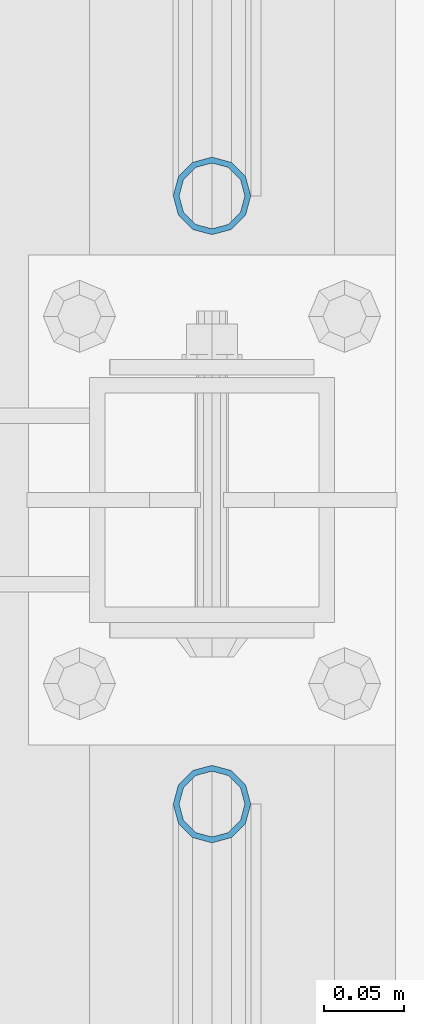
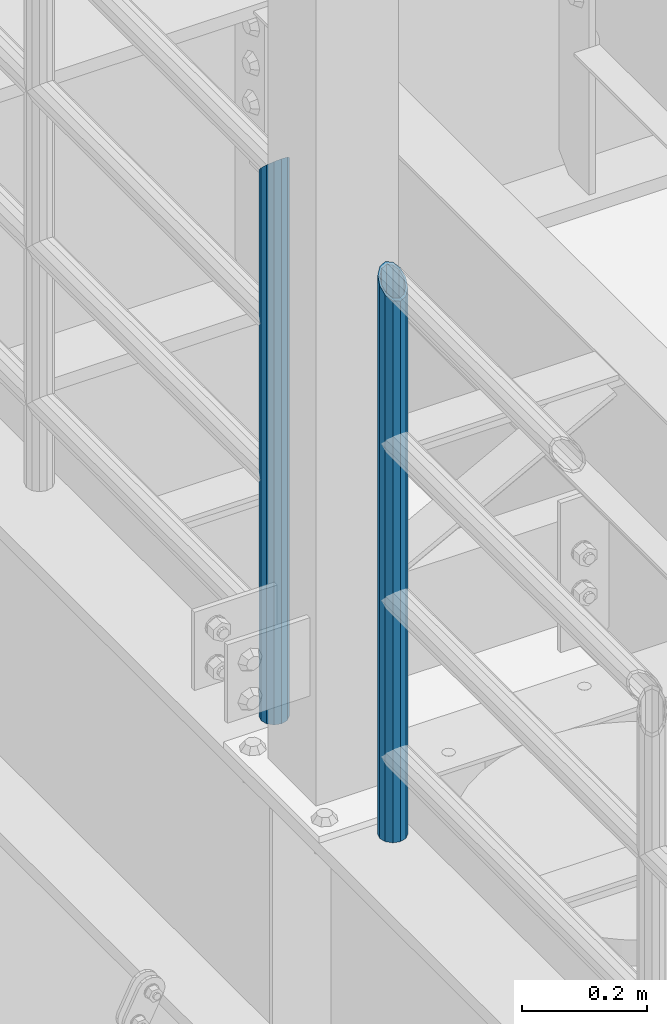
# One storey, part 679 of 1876: 2 columns, 2 elements without a shape of their own.
"""IFC2X3 building model written with IfcOpenShell, lengths in millimetres."""

from ifc_helpers import new_model, si_unit, frame, origin_with_axes, place, context, subcontext, project, spatial, faceted_brep, material, type_object, element, aggregate, save


model = new_model("IFC2X3")

# Units and contexts
model_context = context("Model", 3, precision=1e-05, world=origin_with_axes())
body_context = subcontext(model_context, "Body", "Model", "MODEL_VIEW")
ifc_project = project(units=[si_unit("LENGTHUNIT", "METRE", prefix="MILLI"), si_unit("AREAUNIT", "SQUARE_METRE"), si_unit("VOLUMEUNIT", "CUBIC_METRE"), si_unit("MASSUNIT", "GRAM", prefix="KILO"), si_unit("TIMEUNIT", "SECOND"), si_unit("PLANEANGLEUNIT", "RADIAN"), si_unit("SOLIDANGLEUNIT", "STERADIAN"), si_unit("THERMODYNAMICTEMPERATUREUNIT", "DEGREE_CELSIUS"), si_unit("LUMINOUSINTENSITYUNIT", "LUMEN")], contexts=[model_context])

# Site, building, storey
site_placement = place(None, origin_with_axes())
site = spatial("IfcSite", under=ifc_project, at=site_placement, CompositionType="ELEMENT")
building_placement = place(site_placement, origin_with_axes())
building = spatial("IfcBuilding", under=site, at=building_placement, Name="Undefined", CompositionType="ELEMENT")
storey_placement = place(building_placement, origin_with_axes())
storey = spatial("IfcBuildingStorey", under=building, at=storey_placement, Name="Undefined", CompositionType="ELEMENT", Elevation=0.0)

# Assembly, column
assembly_1_placement = place(storey_placement, origin_with_axes())
assembly_1 = element("IfcElementAssembly", 1, at=assembly_1_placement, inside=storey, Name="RAIL", AssemblyPlace="NOTDEFINED", PredefinedType="RIGID_FRAME")
ifc_material = material()
column_type = type_object("IfcColumnType", Name="PIPE1-1/2SCH40", PredefinedType="NOTDEFINED")
column_1_placement = place(assembly_1_placement, frame((-1.81898940354586e-12, -318.770000000001, 8153.4), z_axis=(0.0, 1.0, 0.0), x_axis=(0.0, 0.0, 1.0)))
column_1 = element("IfcColumn", 2, at=column_1_placement, type_object=column_type, material=ifc_material, Name="POST", ObjectType="PIPE1-1/2SCH40", context=body_context, shape_type="Brep", body=[
    faceted_brep([(0.0, -20.4469999999999, 0.0), (0.0, -17.7076214311803, 10.2235000000001), (1066.1015, -17.7076214311803, 10.2235000000001), (1076.325, -20.4469999999999, 0.0), (0.0, -10.2235000000001, 17.7076214311801), (1058.61737856882, -10.2235000000001, 17.7076214311801), (-1.45519152283669e-11, 0.0, 20.4470000000001), (1055.878, 0.0, 20.4470000000001), (0.0, 10.2235000000001, 17.7076214311801), (1058.61737856882, 10.2235000000001, 17.7076214311801), (0.0, 17.7076214311803, 10.2235000000001), (1066.1015, 17.7076214311803, 10.2235000000001), (0.0, 20.4469999999999, 0.0), (1076.325, 20.4469999999999, 0.0), (0.0, 17.7076214311803, -10.2235000000001), (1086.5485, 17.7076214311803, -10.2235000000001), (0.0, 10.2235000000001, -17.7076214311801), (1094.03262143118, 10.2235000000001, -17.7076214311801), (-1.45519152283669e-11, 0.0, -20.4470000000001), (1096.772, 0.0, -20.4470000000001), (0.0, -10.2235000000001, -17.7076214311801), (1094.03262143118, -10.2235000000001, -17.7076214311801), (0.0, -17.7076214311803, -10.2235000000001), (1086.5485, -17.7076214311803, -10.2235000000001), (0.0, -24.1299999999992, 0.0), (0.0, -20.8971929933184, -12.0649999999996), (1088.39, -20.8971929933184, -12.0649999999996), (1076.325, -24.1300000000001, 0.0), (0.0, -12.0650000000001, -20.8971929933186), (1097.22219299332, -12.0650000000001, -20.8971929933186), (-1.45519152283669e-11, 0.0, -24.130000000001), (1100.455, 0.0, -24.1300000000001), (0.0, 12.0650000000001, -20.8971929933186), (1097.22219299332, 12.0650000000001, -20.8971929933186), (0.0, 20.8971929933184, -12.0649999999996), (1088.39, 20.8971929933184, -12.0649999999996), (0.0, 24.1299999999992, 0.0), (1076.325, 24.1300000000001, 0.0), (0.0, 20.8971929933184, 12.0649999999996), (1064.26, 20.8971929933184, 12.0649999999996), (0.0, 12.0650000000001, 20.8971929933186), (1055.42780700668, 12.0650000000001, 20.8971929933186), (-1.45519152283669e-11, 0.0, 24.130000000001), (1052.195, 0.0, 24.1300000000001), (0.0, -12.0650000000001, 20.8971929933186), (1055.42780700668, -12.0650000000001, 20.8971929933186), (0.0, -20.8971929933184, 12.0649999999996), (1064.26, -20.8971929933184, 12.0649999999996)], [[[0, 1, 2, 3]], [[1, 4, 5, 2]], [[4, 6, 7, 5]], [[6, 8, 9, 7]], [[8, 10, 11, 9]], [[10, 12, 13, 11]], [[12, 14, 15, 13]], [[14, 16, 17, 15]], [[16, 18, 19, 17]], [[18, 20, 21, 19]], [[20, 22, 23, 21]], [[22, 0, 3, 23]], [[24, 25, 26, 27]], [[25, 28, 29, 26]], [[28, 30, 31, 29]], [[30, 32, 33, 31]], [[32, 34, 35, 33]], [[34, 36, 37, 35]], [[36, 38, 39, 37]], [[38, 40, 41, 39]], [[40, 42, 43, 41]], [[42, 44, 45, 43]], [[44, 46, 47, 45]], [[46, 24, 27, 47]], [[29, 31, 33, 35, 37, 39, 41, 43, 45, 47, 27, 26], [5, 7, 9, 11, 13, 15, 17, 19, 21, 23, 3, 2]], [[46, 44, 42, 40, 38, 36, 34, 32, 30, 28, 25, 24], [22, 20, 18, 16, 14, 12, 10, 8, 6, 4, 1, 0]]]),
])
aggregate(assembly_1, [column_1])

assembly_2_placement = place(storey_placement, origin_with_axes())
assembly_2 = element("IfcElementAssembly", 3, at=assembly_2_placement, inside=storey, Name="RAIL", AssemblyPlace="NOTDEFINED", PredefinedType="RIGID_FRAME")
column_2_placement = place(assembly_2_placement, frame((-1.81898940354586e-12, -697.230000000001, 8153.4), z_axis=(0.0, 1.0, 0.0), x_axis=(0.0, 0.0, 1.0)))
column_2 = element("IfcColumn", 4, at=column_2_placement, type_object=column_type, material=ifc_material, Name="POST", ObjectType="PIPE1-1/2SCH40", context=body_context, shape_type="Brep", body=[
    faceted_brep([(0.0, -20.4469999999999, 0.0), (0.0, -17.7076214311803, 10.2235000000001), (1086.54849999999, -17.7076214311801, 10.2235000000001), (1076.325, -20.4469999999999, 0.0), (0.0, -10.2235000000001, 17.7076214311801), (1094.03262143117, -10.2235000000001, 17.7076214311801), (-1.45519152283669e-11, 0.0, 20.4470000000001), (1096.77199999999, 0.0, 20.4470000000001), (0.0, 10.2235000000001, 17.7076214311801), (1094.03262143117, 10.2235000000001, 17.7076214311801), (0.0, 17.7076214311803, 10.2235000000001), (1086.54849999999, 17.7076214311801, 10.2235000000001), (0.0, 20.4469999999999, 0.0), (1076.325, 20.4469999999999, 0.0), (0.0, 17.7076214311803, -10.2235000000001), (1066.10149999999, 17.7076214311801, -10.2235000000001), (0.0, 10.2235000000001, -17.7076214311801), (1058.61737856881, 10.2235000000001, -17.7076214311801), (-1.45519152283669e-11, 0.0, -20.4470000000001), (1055.87799999999, 0.0, -20.4470000000001), (0.0, -10.2235000000001, -17.7076214311801), (1058.61737856881, -10.2235000000001, -17.7076214311801), (0.0, -17.7076214311803, -10.2235000000001), (1066.10149999999, -17.7076214311801, -10.2235000000001), (0.0, -24.1299999999992, 0.0), (0.0, -20.8971929933184, -12.0649999999996), (1064.25999999999, -20.8971929933186, -12.0649999999996), (1076.325, -24.1300000000001, 0.0), (0.0, -12.0650000000001, -20.8971929933186), (1055.42780700667, -12.0649999999996, -20.8971929933186), (-1.45519152283669e-11, 0.0, -24.130000000001), (1052.19499999999, 0.0, -24.1300000000001), (0.0, 12.0650000000001, -20.8971929933186), (1055.42780700667, 12.0649999999996, -20.8971929933186), (0.0, 20.8971929933184, -12.0649999999996), (1064.25999999999, 20.8971929933186, -12.0649999999996), (0.0, 24.1299999999992, 0.0), (1076.325, 24.1300000000001, 0.0), (0.0, 20.8971929933184, 12.0649999999996), (1088.38999999999, 20.8971929933186, 12.0649999999996), (0.0, 12.0650000000001, 20.8971929933186), (1097.22219299331, 12.0649999999996, 20.8971929933186), (-1.45519152283669e-11, 0.0, 24.130000000001), (1100.45499999999, 0.0, 24.1300000000001), (0.0, -12.0650000000001, 20.8971929933186), (1097.22219299331, -12.0649999999996, 20.8971929933186), (0.0, -20.8971929933184, 12.0649999999996), (1088.38999999999, -20.8971929933186, 12.0649999999996)], [[[0, 1, 2, 3]], [[1, 4, 5, 2]], [[4, 6, 7, 5]], [[6, 8, 9, 7]], [[8, 10, 11, 9]], [[10, 12, 13, 11]], [[12, 14, 15, 13]], [[14, 16, 17, 15]], [[16, 18, 19, 17]], [[18, 20, 21, 19]], [[20, 22, 23, 21]], [[22, 0, 3, 23]], [[24, 25, 26, 27]], [[25, 28, 29, 26]], [[28, 30, 31, 29]], [[30, 32, 33, 31]], [[32, 34, 35, 33]], [[34, 36, 37, 35]], [[36, 38, 39, 37]], [[38, 40, 41, 39]], [[40, 42, 43, 41]], [[42, 44, 45, 43]], [[44, 46, 47, 45]], [[46, 24, 27, 47]], [[29, 31, 33, 35, 37, 39, 41, 43, 45, 47, 27, 26], [5, 7, 9, 11, 13, 15, 17, 19, 21, 23, 3, 2]], [[46, 44, 42, 40, 38, 36, 34, 32, 30, 28, 25, 24], [22, 20, 18, 16, 14, 12, 10, 8, 6, 4, 1, 0]]]),
])
aggregate(assembly_2, [column_2])

save(model, "model.ifc")
